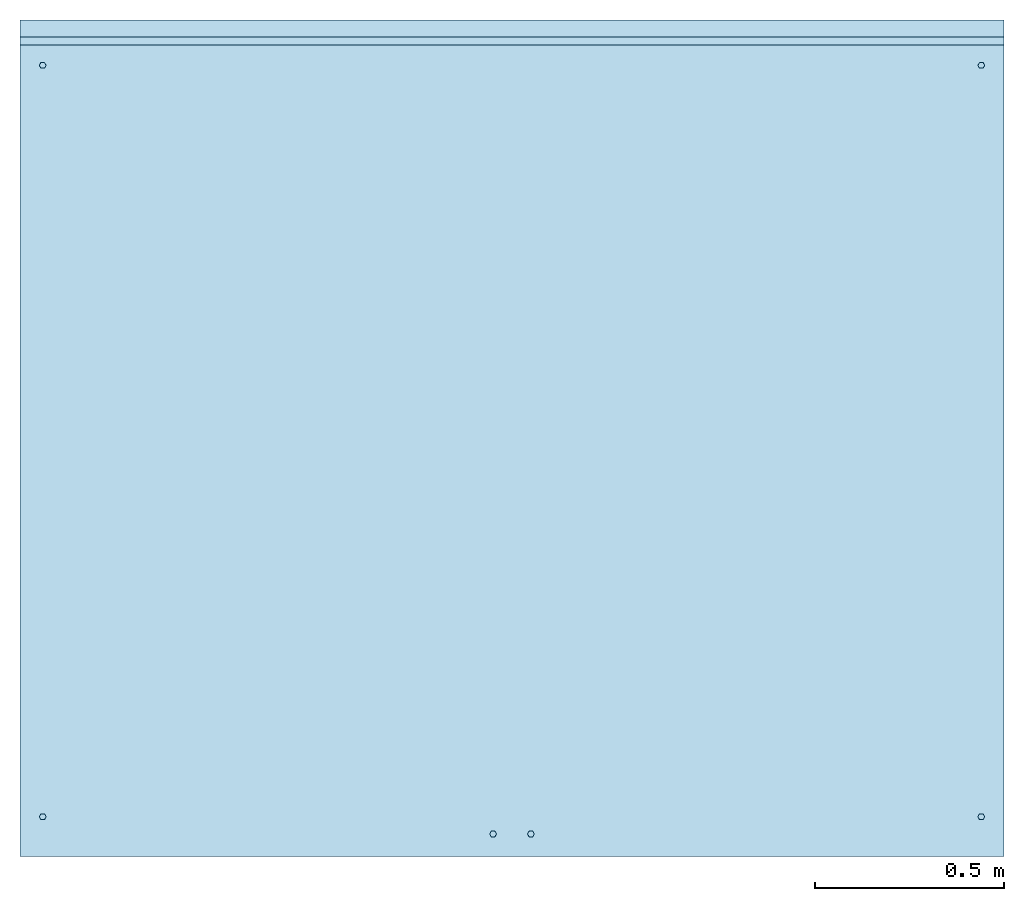
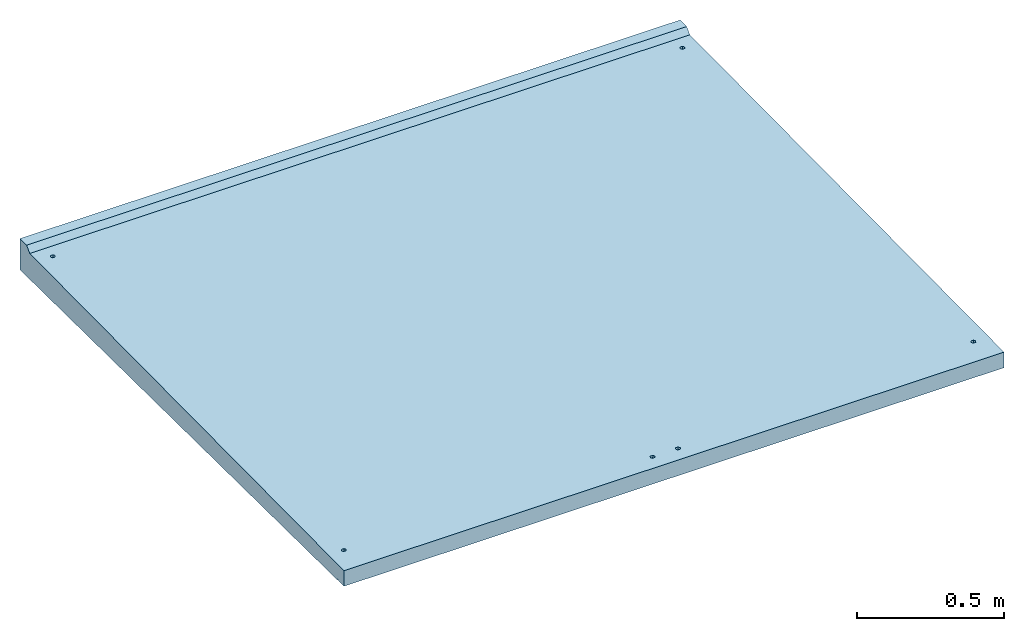
# One storey: 1 slab.
"""IFC2X3 building model written with IfcOpenShell, lengths in millimetres."""

import ifcopenshell
import ifcopenshell.guid

model = None  # the IFC model being written
_history = None  # IfcOwnerHistory: only IFC2X3 demands one
_inside = {}  # id of a spatial element -> (the spatial element, [elements in it])
_under = {}  # id of a project, library or spatial element -> (it, [spatial elements below it])
_declared = {}  # id of a project -> (the project, [libraries it declares])
_typed = {}  # id of a type object -> (the type object, [elements of that type])
_made_of = {}  # id of a material, layer set ... -> (it, [elements and type objects made of it])


def new_model(schema):
    """Start an empty IFC model of exactly this schema.

    Asked for "IFC4X3", IfcOpenShell would pick the latest addendum, in which some entities
    have other attributes; the version numbers below select the first issue.
    IFC2X3 requires an IfcOwnerHistory on every rooted entity: one is made here for all.
    """
    global model, _history
    if schema == "IFC4X3":
        model = ifcopenshell.file(schema_version=(4, 3, 0, 0))
    else:
        model = ifcopenshell.file(schema=schema)
    _inside.clear()
    _under.clear()
    _declared.clear()
    _typed.clear()
    _made_of.clear()
    _history = None
    if model.schema == "IFC2X3":
        org = make("IfcOrganization", Name="unknown")
        user = make(
            "IfcPersonAndOrganization",
            ThePerson=make("IfcPerson", FamilyName="unknown"),
            TheOrganization=org,
        )
        app = make(
            "IfcApplication",
            ApplicationDeveloper=org,
            Version="unknown",
            ApplicationFullName="unknown",
            ApplicationIdentifier="unknown",
        )
        _history = make(
            "IfcOwnerHistory",
            OwningUser=user,
            OwningApplication=app,
            ChangeAction="ADDED",
            CreationDate=0,
        )
    return model


def make(cls, **values):
    """One entity of the class cls with the attributes given. An attribute that is None is left unset."""
    return model.create_entity(
        cls, **{name: value for name, value in values.items() if value is not None}
    )


def entity(cls, *values):
    """Any entity or typed value of the class cls, its attributes in the order of the schema. None: left unset."""
    e = model.create_entity(cls)
    for i, value in enumerate(values):
        if value is not None:
            e[i] = value
    return e


def rooted(cls, **values):
    """An entity with a GlobalId (a new one), such as an element, a storey or a relation."""
    return make(cls, GlobalId=ifcopenshell.guid.new(), OwnerHistory=_history, **values)


def si_unit(unit_type, name, prefix=None):
    """IfcSIUnit, for example si_unit("LENGTHUNIT", "METRE", prefix="MILLI")."""
    return make("IfcSIUnit", UnitType=unit_type, Prefix=prefix, Name=name)


def converted_unit(unit_type, name, factor, base, dimensions=None, offset=None):
    """IfcConversionBasedUnit, such as the inch: factor (a typed value) times the base unit."""
    return make(
        "IfcConversionBasedUnit"
        if offset is None
        else "IfcConversionBasedUnitWithOffset",
        ConversionOffset=offset,
        Dimensions=None
        if dimensions is None
        else entity("IfcDimensionalExponents", *dimensions),
        UnitType=unit_type,
        Name=name,
        ConversionFactor=make(
            "IfcMeasureWithUnit", ValueComponent=factor, UnitComponent=base
        ),
    )


def derived_unit(unit_type, elements):
    """IfcDerivedUnit: a product of units, each with its exponent."""
    return make(
        "IfcDerivedUnit",
        Elements=[
            make("IfcDerivedUnitElement", Unit=unit, Exponent=power)
            for unit, power in elements
        ],
        UnitType=unit_type,
    )


def assignment(units):
    """IfcUnitAssignment: the units of a project."""
    return None if units is None else make("IfcUnitAssignment", Units=units)


def point(xyz):
    """IfcCartesianPoint."""
    return None if xyz is None else make("IfcCartesianPoint", Coordinates=xyz)


def direction(xyz):
    """IfcDirection."""
    return None if xyz is None else make("IfcDirection", DirectionRatios=xyz)


def frame(location, z_axis=None, x_axis=None):
    """IfcAxis2Placement3D, a coordinate frame: its origin and axes. An axis left out is left unset."""
    return make(
        "IfcAxis2Placement3D",
        Location=point(location),
        Axis=direction(z_axis),
        RefDirection=direction(x_axis),
    )


def origin():
    """The frame at (0, 0, 0) with its axes left unset."""
    return frame((0.0, 0.0, 0.0))


def place(relative_to, where):
    """IfcLocalPlacement: puts the frame where relative to a parent placement (None: the world)."""
    return make(
        "IfcLocalPlacement", PlacementRelTo=relative_to, RelativePlacement=where
    )


def context(
    kind, dimensions, precision=None, world=None, true_north=None, identifier=None
):
    """IfcGeometricRepresentationContext, for example the 3D "Model" context."""
    return make(
        "IfcGeometricRepresentationContext",
        ContextIdentifier=identifier,
        ContextType=kind,
        CoordinateSpaceDimension=dimensions,
        Precision=precision,
        WorldCoordinateSystem=world,
        TrueNorth=true_north,
    )


def subcontext(parent, identifier, kind, view, scale=None):
    """IfcGeometricRepresentationSubContext, for example "Body" below "Model"."""
    return make(
        "IfcGeometricRepresentationSubContext",
        ContextIdentifier=identifier,
        ContextType=kind,
        ParentContext=parent,
        TargetScale=scale,
        TargetView=view,
    )


def project(units=None, contexts=None):
    """IfcProject with its units and contexts."""
    return rooted(
        "IfcProject",
        Name="project",
        RepresentationContexts=contexts,
        UnitsInContext=assignment(units),
    )


def spatial(cls, under=None, at=None, **own):
    """A site, building, storey or space (cls), placed at a placement, below another one or the project."""
    s = rooted(cls, ObjectPlacement=at, **own)
    if under is not None:
        _under.setdefault(under.id(), (under, []))[1].append(s)
    return s


def faces_of(points, faces, orient=None, outer=None):
    """IfcFace entities. A face is a list of loops; a loop is a list of indices into points, from 0.

    orient and outer hold one flag for each loop. By default every Orientation is true, the
    first loop of a face is its IfcFaceOuterBound and the others are IfcFaceBound.
    """
    made = []
    for i, loops in enumerate(faces):
        bounds = []
        for j, loop in enumerate(loops):
            is_outer = j == 0 if outer is None else outer[i][j]
            bounds.append(
                make(
                    "IfcFaceOuterBound" if is_outer else "IfcFaceBound",
                    Bound=make("IfcPolyLoop", Polygon=[points[k] for k in loop]),
                    Orientation=True if orient is None else orient[i][j],
                )
            )
        made.append(make("IfcFace", Bounds=bounds))
    return made


def faceted_brep(points, faces, orient=None, outer=None, voids=None):
    """IfcFacetedBrep: a solid bounded by flat faces; with voids (closed shells), ...WithVoids."""
    shared = [point(p) for p in points]
    hull = make("IfcClosedShell", CfsFaces=faces_of(shared, faces, orient, outer))
    if voids is None:
        return make("IfcFacetedBrep", Outer=hull)
    return make(
        "IfcFacetedBrepWithVoids",
        Outer=hull,
        Voids=[
            make(cls, CfsFaces=faces_of(shared, fs, o, b)) for cls, fs, o, b in voids
        ],
    )


def shape(context_of_items, identifier, shape_type, items):
    """IfcShapeRepresentation: the items that make up one representation, for example the "Body"."""
    return make(
        "IfcShapeRepresentation",
        ContextOfItems=context_of_items,
        RepresentationIdentifier=identifier,
        RepresentationType=shape_type,
        Items=items,
    )


def material(Name=None, Category=None):
    """IfcMaterial."""
    return make("IfcMaterial", Name=Name, Category=Category)


def made_of(thing, what):
    """Note that an element or type object is made of a material, layer set ...; save() writes the relation."""
    if what is not None:
        _made_of.setdefault(what.id(), (what, []))[1].append(thing)
    return thing


def type_object(cls, material=None, **own):
    """A type object (cls), such as IfcWallType, which elements share."""
    return made_of(rooted(cls, **own), material)


def element(
    cls,
    number,
    at=None,
    inside=None,
    cuts=None,
    type_object=None,
    material=None,
    context=None,
    identifier="Body",
    shape_type=None,
    held_by="IfcProductDefinitionShape",
    body=None,
    shapes=None,
    **own,
):
    """One element of the class cls, such as IfcWall. Its Tag is "e" and its number.

    at: its placement. inside: the storey or other place that contains it. cuts: it is an
    opening in that element (IfcRelVoidsElement). A single representation is given by context,
    identifier, shape_type and body (its items); several are given by shapes. held_by: the class
    of the entity that holds the representations. save() writes the other relations.
    """
    e = rooted(cls, Tag="e%d" % number, ObjectPlacement=at, **own)
    if body is not None:
        shapes = [shape(context, identifier, shape_type, body)]
    if shapes is not None:
        e.Representation = make(held_by, Representations=shapes)
    if inside is not None:
        _inside.setdefault(inside.id(), (inside, []))[1].append(e)
    if cuts is not None:
        rooted(
            "IfcRelVoidsElement", RelatingBuildingElement=cuts, RelatedOpeningElement=e
        )
    if type_object is not None:
        _typed.setdefault(type_object.id(), (type_object, []))[1].append(e)
    return made_of(e, material)


def aggregate(whole, parts):
    """IfcRelAggregates: a whole, such as a stair, and the parts it consists of."""
    return rooted("IfcRelAggregates", RelatingObject=whole, RelatedObjects=parts)


def save(model, path):
    """Write the relations noted so far, then the file.

    IfcRelAggregates (storeys below a building ...), IfcRelContainedInSpatialStructure (elements
    in a storey), IfcRelDefinesByType, IfcRelAssociatesMaterial and IfcRelDeclares: one each for
    every whole, place, type object, material and project.
    """
    for whole, parts in _under.values():
        aggregate(whole, parts)
    for where, things in _inside.values():
        rooted(
            "IfcRelContainedInSpatialStructure",
            RelatedElements=things,
            RelatingStructure=where,
        )
    for kind, things in _typed.values():
        rooted("IfcRelDefinesByType", RelatedObjects=things, RelatingType=kind)
    for what, things in _made_of.values():
        rooted("IfcRelAssociatesMaterial", RelatedObjects=things, RelatingMaterial=what)
    for by, libraries in _declared.values():
        rooted("IfcRelDeclares", RelatingContext=by, RelatedDefinitions=libraries)
    model.write(path)


model = new_model("IFC2X3")

# Units and contexts
model_context = context("Model", 3, precision=0.01, world=origin(), true_north=direction((6.12303176911189e-17, 1.0)))
body_context = subcontext(model_context, "Body", "Model", "MODEL_VIEW")
ifc_project = project(units=[si_unit("LENGTHUNIT", "METRE", prefix="MILLI"), si_unit("AREAUNIT", "SQUARE_METRE"), si_unit("VOLUMEUNIT", "CUBIC_METRE"), converted_unit("PLANEANGLEUNIT", "DEGREE", entity("IfcRatioMeasure", 0.0174532925199433), si_unit("PLANEANGLEUNIT", "RADIAN"), dimensions=[0, 0, 0, 0, 0, 0, 0]), si_unit("MASSUNIT", "GRAM", prefix="KILO"), derived_unit("MASSDENSITYUNIT", [(si_unit("MASSUNIT", "GRAM", prefix="KILO"), 1), (si_unit("LENGTHUNIT", "METRE"), -3)]), derived_unit("MOMENTOFINERTIAUNIT", [(si_unit("LENGTHUNIT", "METRE"), 4)]), si_unit("TIMEUNIT", "SECOND"), si_unit("FREQUENCYUNIT", "HERTZ"), si_unit("THERMODYNAMICTEMPERATUREUNIT", "DEGREE_CELSIUS"), derived_unit("THERMALTRANSMITTANCEUNIT", [(si_unit("MASSUNIT", "GRAM", prefix="KILO"), 1), (si_unit("THERMODYNAMICTEMPERATUREUNIT", "KELVIN"), -1), (si_unit("TIMEUNIT", "SECOND"), -3)]), derived_unit("VOLUMETRICFLOWRATEUNIT", [(si_unit("LENGTHUNIT", "METRE"), 3), (si_unit("TIMEUNIT", "SECOND"), -1)]), si_unit("ELECTRICCURRENTUNIT", "AMPERE"), si_unit("ELECTRICVOLTAGEUNIT", "VOLT"), si_unit("POWERUNIT", "WATT"), si_unit("FORCEUNIT", "NEWTON", prefix="KILO"), si_unit("ILLUMINANCEUNIT", "LUX"), si_unit("LUMINOUSFLUXUNIT", "LUMEN"), si_unit("LUMINOUSINTENSITYUNIT", "CANDELA"), derived_unit("USERDEFINED", [(si_unit("MASSUNIT", "GRAM", prefix="KILO"), -1), (si_unit("LENGTHUNIT", "METRE"), -2), (si_unit("TIMEUNIT", "SECOND"), 3), (si_unit("LUMINOUSFLUXUNIT", "LUMEN"), 1)]), derived_unit("LINEARVELOCITYUNIT", [(si_unit("LENGTHUNIT", "METRE"), 1), (si_unit("TIMEUNIT", "SECOND"), -1)]), si_unit("PRESSUREUNIT", "PASCAL"), derived_unit("USERDEFINED", [(si_unit("LENGTHUNIT", "METRE"), -2), (si_unit("MASSUNIT", "GRAM", prefix="KILO"), 1), (si_unit("TIMEUNIT", "SECOND"), -2)]), derived_unit("LINEARFORCEUNIT", [(si_unit("MASSUNIT", "GRAM", prefix="KILO"), 1), (si_unit("LENGTHUNIT", "METRE"), 1), (si_unit("TIMEUNIT", "SECOND"), -2), (si_unit("LENGTHUNIT", "METRE"), -1)]), derived_unit("PLANARFORCEUNIT", [(si_unit("MASSUNIT", "GRAM", prefix="KILO"), 1), (si_unit("LENGTHUNIT", "METRE"), 1), (si_unit("TIMEUNIT", "SECOND"), -2), (si_unit("LENGTHUNIT", "METRE"), -2)])], contexts=[model_context])

# Site, building, storey
site_placement = place(None, origin())
site = spatial("IfcSite", under=ifc_project, at=site_placement, CompositionType="ELEMENT")
building_placement = place(site_placement, origin())
building = spatial("IfcBuilding", under=site, at=building_placement, CompositionType="ELEMENT")
storey_placement = place(building_placement, origin())
storey = spatial("IfcBuildingStorey", under=building, at=storey_placement, Name="Begane Grond", CompositionType="ELEMENT", Elevation=0.0)

# Slab
ifc_material = material(Name="beton_prefab-element")
slab_type = type_object("IfcSlabType", PredefinedType="FLOOR", material=ifc_material)
slab_placement = place(storey_placement, frame((-4979.78640975477, -17298.0180129676, -297.649999999983)))
element("IfcSlab", 1, at=slab_placement, inside=storey, type_object=slab_type, Name="23_GM_Standaard con R21:con, 2000x2600x65/115", PredefinedType="FLOOR", context=body_context, shape_type="Brep", body=[
    faceted_brep([(1245.5, 67.0942286340536, 291.110000514584), (1241.0, 59.299999999993, 291.110000514584), (1245.5, 51.5057713659324, 291.110000514584), (1254.5, 51.5057713659324, 291.110000514584), (1259.0, 59.299999999993, 291.110000514584), (1254.5, 67.0942286340536, 291.110000514584), (64.4999999999962, 97.2057713659372, 291.110000514584), (69.0, 105.0, 291.110000514584), (64.4999999999962, 112.794228634058, 291.110000514584), (55.499999999996, 112.794228634058, 291.110000514584), (51.0, 105.0, 291.110000514584), (55.499999999996, 97.2057713659372, 291.110000514584), (2544.5, 97.2057713659307, 291.110000514584), (2549.0, 105.0, 291.110000514584), (2544.5, 112.79422863405, 291.110000514584), (2535.5, 112.79422863405, 291.110000514584), (2531.0, 105.0, 291.110000514584), (2535.5, 97.2057713659307, 291.110000514584), (1345.5, 67.0942286340536, 291.110000514584), (1341.0, 59.299999999993, 291.110000514584), (1345.5, 51.5057713659324, 291.110000514584), (1354.5, 51.5057713659324, 291.110000514584), (1359.0, 59.299999999993, 291.110000514584), (1354.5, 67.0942286340536, 291.110000514584), (55.4999999999993, 2082.20577136594, 310.960000514571), (64.4999999999994, 2082.20577136594, 310.960000514571), (69.0, 2090.0, 310.960000514571), (64.4999999999994, 2097.79422863406, 310.960000514571), (55.4999999999993, 2097.79422863406, 310.960000514571), (51.0, 2090.0, 310.960000514571), (2535.5, 2082.20577136594, 310.960000514571), (2544.5, 2082.20577136594, 310.960000514571), (2549.0, 2090.0, 310.960000514571), (2544.5, 2097.79422863406, 310.960000514571), (2535.5, 2097.79422863406, 310.960000514571), (2531.0, 2090.0, 310.960000514571), (0.0, 2143.53535353534, 351.585353535339), (0.0, 2165.0, 373.05), (0.0, 2210.0, 373.05), (0.0, 2210.0, 243.05), (0.0, 44.9997500187486, 264.700002499813), (0.0, 42.5431741146631, 269.054911778714), (0.0, 37.5434240959141, 269.104909278902), (0.0, 35.0002499812506, 264.799997500187), (0.0, 0.0, 265.15), (0.0, 0.0, 330.15), (2600.0, 42.5431741146631, 269.054911778714), (2600.0, 44.9997500187486, 264.700002499812), (2600.0, 2210.0, 243.05), (2600.0, 2210.0, 373.05), (2600.0, 2165.0, 373.05), (2600.0, 2143.53535353534, 351.585353535339), (2600.0, 0.0, 330.15), (2600.0, 0.0, 265.15), (2600.0, 35.0002499812506, 264.799997500187), (2600.0, 37.5434240959141, 269.104909278902), (65.1125827205766, 97.5931452069538, 331.125931452069), (1244.88741727942, 51.8931452069512, 330.668931452069), (1241.0, 59.299999999993, 330.743), (54.8874172794156, 97.5931452069538, 331.125931452069), (69.0, 105.0, 331.199999999999), (51.0, 105.0, 331.199999999999), (54.8874172794156, 112.40685479304, 331.27406854793), (54.8874172794188, 2082.59314520695, 350.975931452056), (65.1125827205788, 2082.59314520695, 350.975931452056), (65.1125827205766, 112.40685479304, 331.27406854793), (1244.88741727942, 66.706854793037, 330.81706854793), (1255.11258272058, 66.706854793037, 330.81706854793), (69.0, 2090.0, 351.049999999986), (2531.0, 2090.0, 351.049999999986), (1344.88741727942, 66.7068547930349, 330.81706854793), (1259.0, 59.299999999993, 330.743), (1341.0, 59.299999999993, 330.743), (1255.11258272058, 51.8931452069512, 330.668931452069), (1344.88741727942, 51.8931452069512, 330.668931452069), (2534.88741727942, 2082.59314520695, 350.975931452056), (1355.11258272058, 66.7068547930349, 330.81706854793), (2534.88741727941, 112.406854793031, 331.27406854793), (2531.0, 105.0, 331.199999999999), (1359.0, 59.299999999993, 330.743), (2534.88741727941, 97.5931452069451, 331.125931452069), (1355.11258272058, 51.8931452069512, 330.668931452069), (2545.11258272058, 97.5931452069451, 331.125931452069), (2549.0, 105.0, 331.199999999999), (2545.11258272058, 112.406854793031, 331.27406854793), (2545.11258272058, 2082.59314520695, 350.975931452056), (2549.0, 2090.0, 351.049999999986), (2545.11258272058, 2097.40685479304, 351.124068547916), (2534.88741727942, 2097.40685479304, 351.124068547916), (51.0, 2090.0, 351.049999999986), (54.8874172794177, 2097.40685479304, 351.124068547916), (65.1125827205788, 2097.40685479304, 351.124068547916)], [[[0, 1, 2, 3, 4, 5]], [[6, 7, 8, 9, 10, 11]], [[12, 13, 14, 15, 16, 17]], [[18, 19, 20, 21, 22, 23]], [[24, 25, 26, 27, 28, 29]], [[30, 31, 32, 33, 34, 35]], [[36, 37, 38, 39, 40, 41, 42, 43, 44, 45]], [[46, 47, 48, 49, 50, 51, 52, 53, 54, 55]], [[45, 44, 53, 52]], [[56, 57, 58]], [[57, 56, 45]], [[56, 59, 45]], [[60, 56, 58]], [[59, 61, 45]], [[45, 61, 36]], [[62, 36, 61]], [[62, 63, 36]], [[63, 62, 64]], [[64, 62, 65]], [[60, 66, 65]], [[64, 65, 66]], [[66, 60, 58]], [[64, 66, 67]], [[68, 64, 67]], [[68, 67, 69]], [[69, 67, 70]], [[67, 71, 70]], [[72, 70, 71]], [[73, 72, 71]], [[73, 57, 45]], [[45, 74, 73]], [[74, 72, 73]], [[69, 70, 75]], [[75, 70, 76]], [[75, 76, 77]], [[77, 76, 78]], [[79, 78, 76]], [[79, 80, 78]], [[81, 80, 79]], [[81, 74, 52]], [[80, 81, 52]], [[82, 80, 52]], [[83, 82, 52]], [[52, 51, 83]], [[74, 45, 52]], [[84, 83, 51]], [[85, 84, 51]], [[51, 86, 85]], [[87, 86, 51]], [[87, 51, 88]], [[88, 51, 36]], [[89, 36, 63]], [[36, 89, 90]], [[36, 90, 91]], [[36, 91, 88]], [[88, 91, 69]], [[84, 85, 75]], [[75, 77, 84]], [[69, 91, 68]], [[39, 38, 49, 48]], [[40, 39, 48, 47]], [[44, 43, 54, 53]], [[47, 46, 41, 40]], [[46, 55, 42, 41]], [[55, 54, 43, 42]], [[37, 36, 51, 50]], [[38, 37, 50, 49]], [[59, 11, 10]], [[10, 61, 59]], [[59, 56, 6, 11]], [[80, 82, 12, 17]], [[56, 7, 6]], [[7, 56, 60]], [[65, 8, 7]], [[7, 60, 65]], [[65, 62, 9, 8]], [[84, 77, 15, 14]], [[62, 10, 9]], [[10, 62, 61]], [[80, 17, 16]], [[16, 78, 80]], [[82, 13, 12]], [[13, 82, 83]], [[84, 14, 13]], [[13, 83, 84]], [[77, 16, 15]], [[16, 77, 78]], [[63, 24, 29]], [[29, 89, 63]], [[63, 64, 25, 24]], [[75, 85, 31, 30]], [[64, 26, 25]], [[26, 64, 68]], [[91, 27, 26]], [[26, 68, 91]], [[91, 90, 28, 27]], [[87, 88, 34, 33]], [[90, 29, 28]], [[29, 90, 89]], [[75, 30, 35]], [[35, 69, 75]], [[85, 32, 31]], [[32, 85, 86]], [[87, 33, 32]], [[32, 86, 87]], [[88, 35, 34]], [[35, 88, 69]], [[57, 2, 1]], [[1, 58, 57]], [[57, 73, 3, 2]], [[74, 81, 21, 20]], [[73, 4, 3]], [[4, 73, 71]], [[67, 5, 4]], [[4, 71, 67]], [[67, 66, 0, 5]], [[76, 70, 18, 23]], [[66, 1, 0]], [[1, 66, 58]], [[74, 20, 19]], [[19, 72, 74]], [[81, 22, 21]], [[22, 81, 79]], [[76, 23, 22]], [[22, 79, 76]], [[70, 19, 18]], [[19, 70, 72]]]),
    faceted_brep([(2200.0, 2178.0, 243.37), (2200.0, 2058.0, 244.57), (2200.0, 2058.0, 0.0), (2200.0, 2178.0, 0.0), (1700.0, 2178.0, 0.0), (1700.0, 2058.0, 0.0), (1700.0, 2058.0, 244.57), (1700.0, 2178.0, 243.37), (2030.5, 2178.0, 150.473720558372), (2036.0, 2178.0, 160.0), (2019.5, 2178.0, 150.473720558372), (1880.5, 2178.0, 150.473720558372), (1869.5, 2178.0, 150.473720558372), (1864.0, 2178.0, 160.0), (1869.5, 2178.0, 169.526279441629), (1880.5, 2178.0, 169.526279441629), (2030.5, 2178.0, 169.526279441629), (2019.5, 2178.0, 169.526279441629), (1886.0, 2178.0, 160.0), (2014.0, 2178.0, 160.0), (2036.0, 2058.0, 160.0), (2030.5, 2058.0, 169.52627944163), (2019.5, 2058.0, 169.52627944163), (1880.5, 2058.0, 169.52627944163), (1869.5, 2058.0, 169.52627944163), (1864.0, 2058.0, 160.0), (2019.5, 2058.0, 150.473720558372), (1869.5, 2058.0, 150.473720558372), (1880.5, 2058.0, 150.473720558372), (2030.5, 2058.0, 150.473720558372), (2014.0, 2058.0, 160.0), (1886.0, 2058.0, 160.0)], [[[0, 1, 2, 3]], [[4, 5, 6, 7]], [[1, 0, 7, 6]], [[3, 8, 9]], [[8, 3, 10]], [[3, 4, 10]], [[9, 0, 3]], [[11, 10, 4]], [[4, 12, 11]], [[12, 4, 13]], [[7, 13, 4]], [[13, 7, 14]], [[15, 14, 7]], [[15, 7, 0]], [[0, 9, 16]], [[16, 17, 0]], [[0, 17, 15]], [[18, 15, 17]], [[19, 10, 11]], [[11, 18, 19]], [[19, 18, 17]], [[3, 2, 5, 4]], [[1, 20, 2]], [[20, 1, 21]], [[22, 21, 1]], [[1, 23, 22]], [[23, 1, 6]], [[24, 23, 6]], [[6, 25, 24]], [[25, 6, 5]], [[2, 26, 5]], [[5, 27, 25]], [[27, 5, 28]], [[28, 5, 26]], [[2, 29, 26]], [[26, 30, 28]], [[22, 31, 30]], [[31, 28, 30]], [[23, 31, 22]], [[29, 2, 20]], [[27, 12, 13, 25]], [[27, 28, 11, 12]], [[26, 29, 8, 10]], [[31, 18, 11, 28]], [[23, 15, 18, 31]], [[23, 24, 14, 15]], [[21, 22, 17, 16]], [[25, 13, 14, 24]], [[26, 10, 19, 30]], [[20, 9, 8, 29]], [[21, 16, 9, 20]], [[22, 30, 19, 17]]]),
    faceted_brep([(900.0, 2178.0, 243.37), (900.0, 2058.0, 244.57), (900.0, 2058.0, 0.0), (900.0, 2178.0, 0.0), (400.0, 2178.0, 0.0), (400.0, 2058.0, 0.0), (400.0, 2058.0, 244.57), (400.0, 2178.0, 243.37), (730.5, 2178.0, 150.473720558372), (736.0, 2178.0, 160.0), (719.499999999999, 2178.0, 150.473720558372), (580.5, 2178.0, 150.473720558372), (569.499999999999, 2178.0, 150.473720558372), (564.0, 2178.0, 160.0), (569.499999999999, 2178.0, 169.526279441629), (580.5, 2178.0, 169.526279441629), (730.5, 2178.0, 169.526279441629), (719.499999999999, 2178.0, 169.526279441629), (586.0, 2178.0, 160.0), (714.0, 2178.0, 160.0), (736.0, 2058.0, 160.0), (730.5, 2058.0, 169.52627944163), (719.499999999999, 2058.0, 169.52627944163), (580.5, 2058.0, 169.52627944163), (569.499999999999, 2058.0, 169.52627944163), (564.0, 2058.0, 160.0), (719.499999999999, 2058.0, 150.473720558372), (569.499999999999, 2058.0, 150.473720558372), (580.499999999999, 2058.0, 150.473720558372), (730.5, 2058.0, 150.473720558372), (714.0, 2058.0, 160.0), (586.0, 2058.0, 160.0)], [[[0, 1, 2, 3]], [[4, 5, 6, 7]], [[1, 0, 7, 6]], [[3, 8, 9]], [[8, 3, 10]], [[3, 4, 10]], [[9, 0, 3]], [[11, 10, 4]], [[4, 12, 11]], [[12, 4, 13]], [[7, 13, 4]], [[13, 7, 14]], [[15, 14, 7]], [[15, 7, 0]], [[0, 9, 16]], [[16, 17, 0]], [[0, 17, 15]], [[18, 15, 17]], [[19, 10, 11]], [[11, 18, 19]], [[19, 18, 17]], [[3, 2, 5, 4]], [[1, 20, 2]], [[20, 1, 21]], [[22, 21, 1]], [[1, 23, 22]], [[23, 1, 6]], [[24, 23, 6]], [[6, 25, 24]], [[25, 6, 5]], [[2, 26, 5]], [[5, 27, 25]], [[27, 5, 28]], [[28, 5, 26]], [[2, 29, 26]], [[26, 30, 28]], [[22, 31, 30]], [[31, 28, 30]], [[23, 31, 22]], [[29, 2, 20]], [[27, 12, 13, 25]], [[27, 28, 11, 12]], [[26, 29, 8, 10]], [[31, 18, 11, 28]], [[23, 15, 18, 31]], [[23, 24, 14, 15]], [[21, 22, 17, 16]], [[25, 13, 14, 24]], [[26, 10, 19, 30]], [[20, 9, 8, 29]], [[21, 16, 9, 20]], [[22, 30, 19, 17]]]),
])

save(model, "model.ifc")
